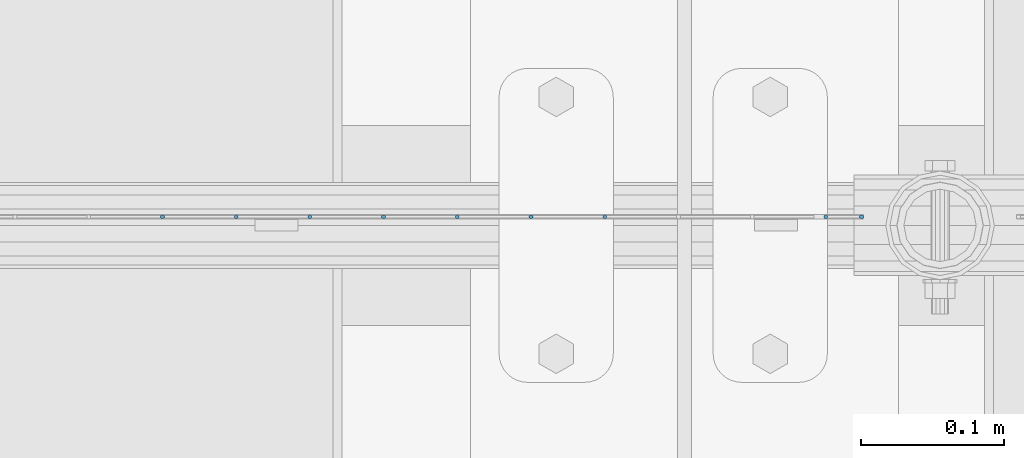
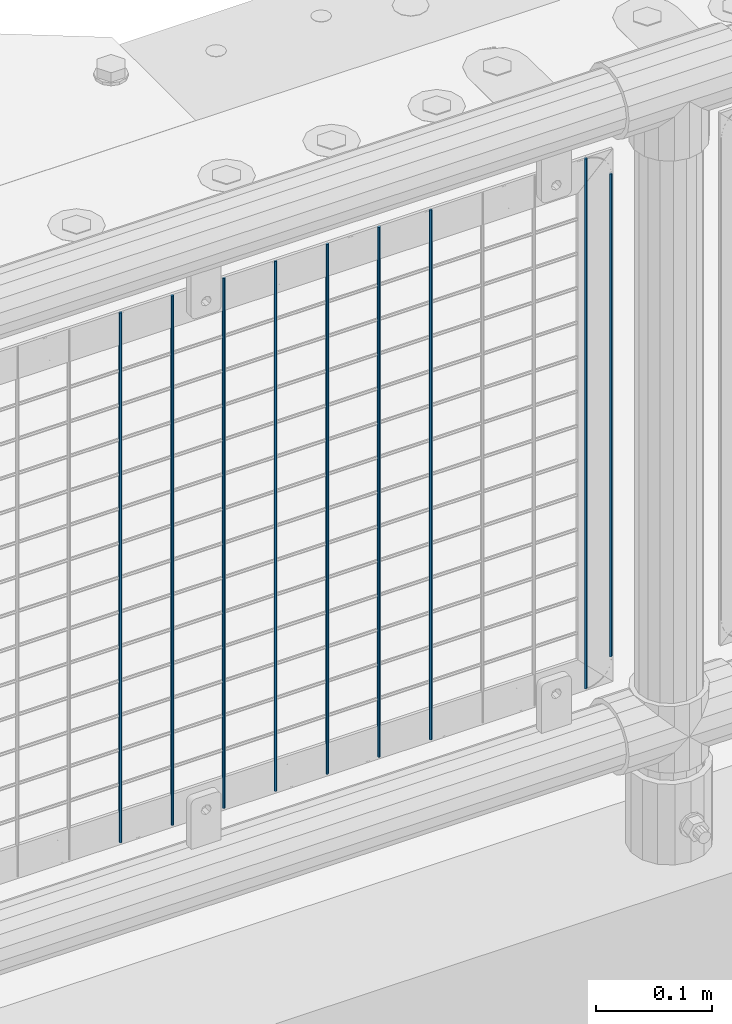
# One storey, part 76 of 193: 9 columns.
"""IFC2X3 building model written with IfcOpenShell, lengths in millimetres."""

from ifc_helpers import new_model, si_unit, frame, origin_with_axes, place, context, subcontext, project, spatial, faceted_brep, material, type_object, element, save


model = new_model("IFC2X3")

# Units and contexts
model_context = context("Model", 3, precision=1e-05, world=origin_with_axes())
body_context = subcontext(model_context, "Body", "Model", "MODEL_VIEW")
ifc_project = project(units=[si_unit("LENGTHUNIT", "METRE", prefix="MILLI"), si_unit("AREAUNIT", "SQUARE_METRE"), si_unit("VOLUMEUNIT", "CUBIC_METRE"), si_unit("MASSUNIT", "GRAM", prefix="KILO"), si_unit("TIMEUNIT", "SECOND"), si_unit("PLANEANGLEUNIT", "RADIAN"), si_unit("SOLIDANGLEUNIT", "STERADIAN"), si_unit("THERMODYNAMICTEMPERATUREUNIT", "DEGREE_CELSIUS"), si_unit("LUMINOUSINTENSITYUNIT", "LUMEN")], contexts=[model_context])

# Site, building, storey
site_placement = place(None, origin_with_axes())
site = spatial("IfcSite", under=ifc_project, at=site_placement, CompositionType="ELEMENT")
building_placement = place(site_placement, origin_with_axes())
building = spatial("IfcBuilding", under=site, at=building_placement, Name="Standard", CompositionType="ELEMENT")
storey_placement = place(building_placement, origin_with_axes())
storey = spatial("IfcBuildingStorey", under=building, at=storey_placement, Name="Undefined", CompositionType="ELEMENT", Elevation=0.0)

# Columns
ifc_material = material(Name="Misc_Undefined")
column_type = type_object("IfcColumnType", Name="D3", PredefinedType="NOTDEFINED")
for number, where, z_axis, x_axis in (
    (1, (-32115.97, 28670.5, 353.020000000001), (-1.0, 0.0, 0.0), (0.0, 0.0, 1.0)),
    (2, (-32167.625, 28670.5, 353.020000000001), (-1.0, 0.0, 0.0), (0.0, 0.0, 1.0)),
    (3, (-32219.28, 28670.5, 353.020000000001), (-1.0, 0.0, 0.0), (0.0, 0.0, 1.0)),
    (4, (-32270.935, 28670.5, 353.020000000001), (-1.0, 0.0, 0.0), (0.0, 0.0, 1.0)),
    (5, (-32322.59, 28670.5, 353.020000000001), (-1.0, 0.0, 0.0), (0.0, 0.0, 1.0)),
    (6, (-32374.245, 28670.5, 353.020000000001), (-1.0, 0.0, 0.0), (0.0, 0.0, 1.0)),
    (7, (-32425.9, 28670.5, 353.020000000001), (-1.0, 0.0, 0.0), (0.0, 0.0, 1.0)),
    (8, (-31961.005, 28670.5, 353.020000000001), (-1.0, 0.0, 0.0), (0.0, 0.0, 1.0)),
):
    element("IfcColumn", number, at=place(storey_placement, frame(where, z_axis=z_axis, x_axis=x_axis)), inside=storey, type_object=column_type, material=ifc_material, ObjectType="D3", context=body_context, shape_type="Brep", body=[
        faceted_brep([(0.0, -1.49999999999636, 3.63797880709171e-12), (0.0, -0.75, -1.29903810567669), (560.0, -0.75, -1.29903810567703), (560.0, -1.5, 0.0), (0.0, 0.75, -1.29903810567669), (560.0, 0.75, -1.29903810567703), (0.0, 1.50000000000364, 7.27595761418343e-12), (560.0, 1.5, 0.0), (0.0, 0.75, 1.29903810567669), (560.0, 0.75, 1.29903810567703), (0.0, -0.75, 1.29903810567669), (560.0, -0.75, 1.29903810567703)], [[[0, 1, 2, 3]], [[1, 4, 5, 2]], [[4, 6, 7, 5]], [[6, 8, 9, 7]], [[8, 10, 11, 9]], [[10, 0, 3, 11]], [[5, 7, 9, 11, 3, 2]], [[10, 8, 6, 4, 1, 0]]]),
    ])
column_placement = place(storey_placement, frame((-31936.0, 28670.5, 378.020000000001), z_axis=(-1.0, 0.0, 0.0), x_axis=(0.0, 0.0, 1.0)))
element("IfcColumn", 9, at=column_placement, inside=storey, type_object=column_type, material=ifc_material, ObjectType="D3", context=body_context, shape_type="Brep", body=[
    faceted_brep([(0.0, -1.49999999999636, 3.63797880709171e-12), (0.0, -0.75, -1.29903810567669), (510.0, -0.75, -1.29903810567703), (510.0, -1.5, 0.0), (0.0, 0.75, -1.29903810567669), (510.0, 0.75, -1.29903810567703), (0.0, 1.50000000000364, 7.27595761418343e-12), (510.0, 1.5, 0.0), (0.0, 0.75, 1.29903810567669), (510.0, 0.75, 1.29903810567703), (0.0, -0.75, 1.29903810567669), (510.0, -0.75, 1.29903810567703)], [[[0, 1, 2, 3]], [[1, 4, 5, 2]], [[4, 6, 7, 5]], [[6, 8, 9, 7]], [[8, 10, 11, 9]], [[10, 0, 3, 11]], [[5, 7, 9, 11, 3, 2]], [[10, 8, 6, 4, 1, 0]]]),
])

save(model, "model.ifc")
